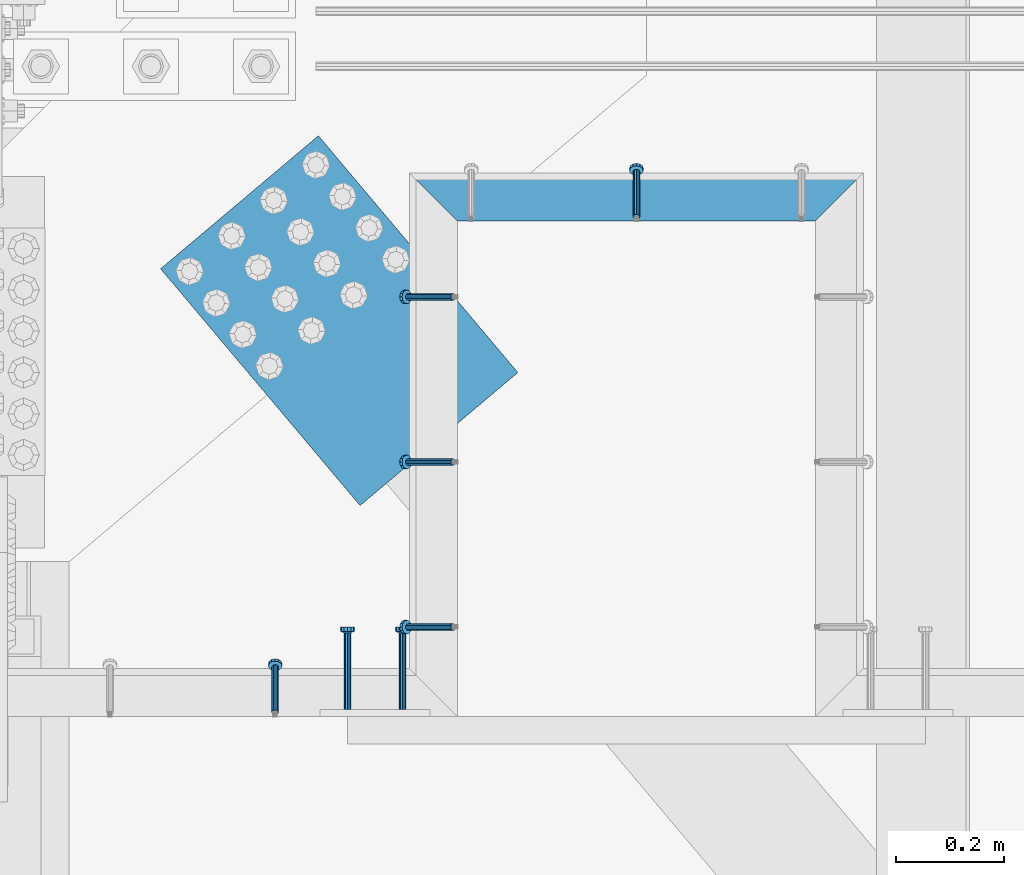
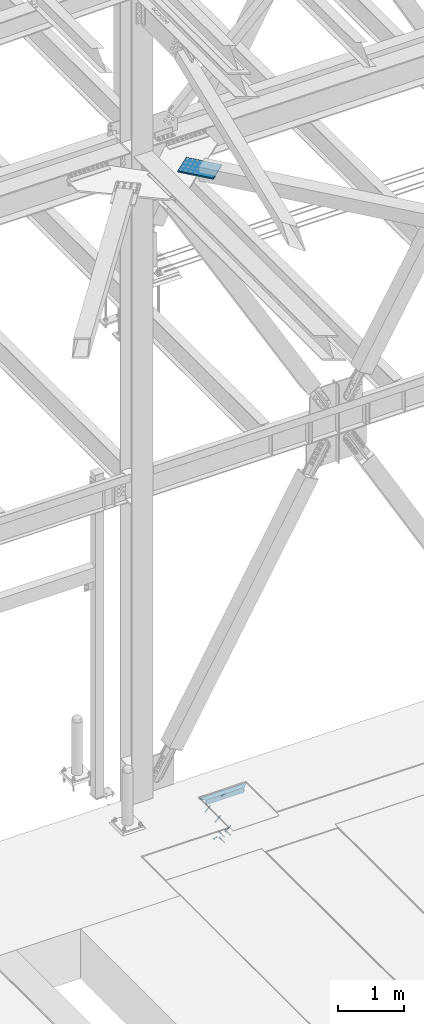
# One storey, part 2504 of 3843: 5 beams, 5 members, 5 elements without a shape of their own.
"""IFC2X3 building model written with IfcOpenShell, lengths in millimetres."""

from ifc_helpers import new_model, si_unit, frame, origin_with_axes, place, context, subcontext, project, spatial, faceted_brep, material, type_object, element, aggregate, save


model = new_model("IFC2X3")

# Units and contexts
model_context = context("Model", 3, precision=1e-05, world=origin_with_axes())
body_context = subcontext(model_context, "Body", "Model", "MODEL_VIEW")
ifc_project = project(units=[si_unit("LENGTHUNIT", "METRE", prefix="MILLI"), si_unit("AREAUNIT", "SQUARE_METRE"), si_unit("VOLUMEUNIT", "CUBIC_METRE"), si_unit("MASSUNIT", "GRAM", prefix="KILO"), si_unit("TIMEUNIT", "SECOND"), si_unit("PLANEANGLEUNIT", "RADIAN"), si_unit("SOLIDANGLEUNIT", "STERADIAN"), si_unit("THERMODYNAMICTEMPERATUREUNIT", "DEGREE_CELSIUS"), si_unit("LUMINOUSINTENSITYUNIT", "LUMEN")], contexts=[model_context])

# Site, building, storey
site_placement = place(None, origin_with_axes())
site = spatial("IfcSite", under=ifc_project, at=site_placement, CompositionType="ELEMENT")
building_placement = place(site_placement, origin_with_axes())
building = spatial("IfcBuilding", under=site, at=building_placement, Name="Undefined", CompositionType="ELEMENT")
storey_placement = place(building_placement, origin_with_axes())
storey = spatial("IfcBuildingStorey", under=building, at=storey_placement, Name="Undefined", CompositionType="ELEMENT", Elevation=0.0)

# Assembly, member
assembly_1_placement = place(storey_placement, origin_with_axes())
assembly_1 = element("IfcElementAssembly", 1, at=assembly_1_placement, inside=storey, Name="EMBED_ANGLE", AssemblyPlace="NOTDEFINED", PredefinedType="RIGID_FRAME")
ifc_material_1 = material(Name="STEEL/A108")
member_type = type_object("IfcMemberType", PredefinedType="NOTDEFINED")
member_1_placement = place(assembly_1_placement, frame((50197.5001822152, 91631.9607012059, 30446.6625), z_axis=(-1.0, 0.0, 0.0), x_axis=(5.70000238222118e-08, 0.707106781186546, -0.707106781186546)))
member_1 = element("IfcMember", 2, at=member_1_placement, type_object=member_type, material=ifc_material_1, Name="HEADED STUD ANCHOR", context=body_context, shape_type="Brep", body=[
    faceted_brep([(7.27595761418343e-12, -3.18000006675175, 5.5), (0.0, -5.49999999998363, 3.1800000667572), (118.110000000976, -5.49999999999091, 3.1800000667572), (118.110000000983, -3.18000006675175, 5.5), (0.0, -6.3499999046162, 0.0), (118.110000000968, -6.34999990461256, 0.0), (0.0, -5.49999999998363, -3.1800000667572), (118.110000000976, -5.49999999999091, -3.1800000667572), (7.27595761418343e-12, -3.18000006675175, -5.5), (118.110000000983, -3.18000006675175, -5.5), (7.27595761418343e-12, -1.81898940354586e-12, -6.34999990463257), (118.110000000968, -1.81898940354586e-12, -6.34999990463257), (0.0, 3.18000006675175, -5.5), (118.110000000968, 3.18000006674811, -5.5), (7.27595761418343e-12, 5.49999999998363, -3.1800000667572), (118.110000000983, 5.49999999998363, -3.1800000667572), (7.27595761418343e-12, 6.3499999046162, 0.0), (118.110000000976, 6.34999990461256, 0.0), (7.27595761418343e-12, 5.49999999998363, 3.1800000667572), (118.110000000983, 5.49999999998363, 3.1800000667572), (0.0, 3.18000006675175, 5.5), (118.110000000968, 3.18000006674811, 5.5), (7.27595761418343e-12, -1.81898940354586e-12, 6.34999990463257), (118.110000000968, -1.81898940354586e-12, 6.34999990463257), (120.650000000991, -10.9899997710909, 6.34999990463257), (120.650000000998, -6.34000015257152, 10.9899997711182), (120.650000000991, -12.6999998092379, 0.0), (120.650000000991, -10.9899997710909, -6.34999990463257), (120.650000000998, -6.34000015257152, -10.9899997711182), (120.650000000991, -1.81898940354586e-12, -12.6899995803833), (120.650000000991, 6.34000015257152, -10.9899997711182), (120.650000000998, 10.9899997710909, -6.34999990463257), (120.650000000991, 12.6999998092342, 0.0), (120.650000000998, 10.9899997710909, 6.34999990463257), (120.650000000991, 6.34000015257152, 10.9899997711182), (120.650000000991, -1.81898940354586e-12, 12.6899995803833), (127.000000001048, -10.9899997710945, 6.34999990463257), (127.000000001048, -6.34000015257152, 10.9899997711182), (127.000000001048, -12.6999998092342, 0.0), (127.000000001048, -10.9899997710945, -6.34999990463257), (127.000000001048, -6.34000015257152, -10.9899997711182), (127.000000001048, 1.81898940354586e-12, -12.6899995803833), (127.000000001048, 6.34000015256788, -10.9899997711182), (127.000000001048, 10.9899997710909, -6.34999990463257), (127.000000001048, 12.6999998092379, 0.0), (127.000000001048, 10.9899997710909, 6.34999990463257), (127.000000001048, 6.34000015256788, 10.9899997711182), (127.000000001048, 1.81898940354586e-12, 12.6899995803833)], [[[0, 1, 2, 3]], [[1, 4, 5, 2]], [[4, 6, 7, 5]], [[6, 8, 9, 7]], [[8, 10, 11, 9]], [[10, 12, 13, 11]], [[12, 14, 15, 13]], [[14, 16, 17, 15]], [[16, 18, 19, 17]], [[18, 20, 21, 19]], [[20, 22, 23, 21]], [[22, 0, 3, 23]], [[22, 20, 18, 16, 14, 12, 10, 8, 6, 4, 1, 0]], [[3, 2, 24, 25]], [[2, 5, 26, 24]], [[5, 7, 27, 26]], [[7, 9, 28, 27]], [[9, 11, 29, 28]], [[11, 13, 30, 29]], [[13, 15, 31, 30]], [[15, 17, 32, 31]], [[17, 19, 33, 32]], [[19, 21, 34, 33]], [[21, 23, 35, 34]], [[23, 3, 25, 35]], [[25, 24, 36, 37]], [[24, 26, 38, 36]], [[26, 27, 39, 38]], [[27, 28, 40, 39]], [[28, 29, 41, 40]], [[29, 30, 42, 41]], [[30, 31, 43, 42]], [[31, 32, 44, 43]], [[32, 33, 45, 44]], [[33, 34, 46, 45]], [[34, 35, 47, 46]], [[35, 25, 37, 47]], [[38, 39, 40, 41, 42, 43, 44, 45, 46, 47, 37, 36]]]),
])

# Assembly, members
assembly_2_placement = place(storey_placement, origin_with_axes())
assembly_2 = element("IfcElementAssembly", 3, at=assembly_2_placement, inside=storey, Name="EMBED_ANGLE", AssemblyPlace="NOTDEFINED", PredefinedType="RIGID_FRAME")
member_2_placement = place(assembly_2_placement, frame((49859.3745199416, 91484.3230038509, 30446.6625), z_axis=(0.0, -1.0, 0.0), x_axis=(-0.707106781186548, 0.0, -0.707106781186548)))
member_2 = element("IfcMember", 4, at=member_2_placement, type_object=member_type, material=ifc_material_1, Name="HEADED STUD ANCHOR", context=body_context, shape_type="Brep", body=[
    faceted_brep([(7.27595761418343e-12, -3.18000006675175, 5.5), (0.0, -5.49999999998363, 3.1800000667572), (118.110000000976, -5.49999999999091, 3.1800000667572), (118.110000000983, -3.18000006675175, 5.5), (0.0, -6.3499999046162, 0.0), (118.110000000968, -6.34999990461256, 0.0), (0.0, -5.49999999998363, -3.1800000667572), (118.110000000976, -5.49999999999091, -3.1800000667572), (7.27595761418343e-12, -3.18000006675175, -5.5), (118.110000000983, -3.18000006675175, -5.5), (7.27595761418343e-12, -1.81898940354586e-12, -6.34999990463257), (118.110000000968, -1.81898940354586e-12, -6.34999990463257), (0.0, 3.18000006675175, -5.5), (118.110000000968, 3.18000006674811, -5.5), (7.27595761418343e-12, 5.49999999998363, -3.1800000667572), (118.110000000983, 5.49999999998363, -3.1800000667572), (7.27595761418343e-12, 6.3499999046162, 0.0), (118.110000000976, 6.34999990461256, 0.0), (7.27595761418343e-12, 5.49999999998363, 3.1800000667572), (118.110000000983, 5.49999999998363, 3.1800000667572), (0.0, 3.18000006675175, 5.5), (118.110000000968, 3.18000006674811, 5.5), (7.27595761418343e-12, -1.81898940354586e-12, 6.34999990463257), (118.110000000968, -1.81898940354586e-12, 6.34999990463257), (120.650000000991, -10.9899997710909, 6.34999990463257), (120.650000000998, -6.34000015257152, 10.9899997711182), (120.650000000991, -12.6999998092379, 0.0), (120.650000000991, -10.9899997710909, -6.34999990463257), (120.650000000998, -6.34000015257152, -10.9899997711182), (120.650000000991, -1.81898940354586e-12, -12.6899995803833), (120.650000000991, 6.34000015257152, -10.9899997711182), (120.650000000998, 10.9899997710909, -6.34999990463257), (120.650000000991, 12.6999998092342, 0.0), (120.650000000998, 10.9899997710909, 6.34999990463257), (120.650000000991, 6.34000015257152, 10.9899997711182), (120.650000000991, -1.81898940354586e-12, 12.6899995803833), (127.000000001048, -10.9899997710945, 6.34999990463257), (127.000000001048, -6.34000015257152, 10.9899997711182), (127.000000001048, -12.6999998092342, 0.0), (127.000000001048, -10.9899997710945, -6.34999990463257), (127.000000001048, -6.34000015257152, -10.9899997711182), (127.000000001048, 1.81898940354586e-12, -12.6899995803833), (127.000000001048, 6.34000015256788, -10.9899997711182), (127.000000001048, 10.9899997710909, -6.34999990463257), (127.000000001048, 12.6999998092379, 0.0), (127.000000001048, 10.9899997710909, 6.34999990463257), (127.000000001048, 6.34000015256788, 10.9899997711182), (127.000000001048, 1.81898940354586e-12, 12.6899995803833)], [[[0, 1, 2, 3]], [[1, 4, 5, 2]], [[4, 6, 7, 5]], [[6, 8, 9, 7]], [[8, 10, 11, 9]], [[10, 12, 13, 11]], [[12, 14, 15, 13]], [[14, 16, 17, 15]], [[16, 18, 19, 17]], [[18, 20, 21, 19]], [[20, 22, 23, 21]], [[22, 0, 3, 23]], [[22, 20, 18, 16, 14, 12, 10, 8, 6, 4, 1, 0]], [[3, 2, 24, 25]], [[2, 5, 26, 24]], [[5, 7, 27, 26]], [[7, 9, 28, 27]], [[9, 11, 29, 28]], [[11, 13, 30, 29]], [[13, 15, 31, 30]], [[15, 17, 32, 31]], [[17, 19, 33, 32]], [[19, 21, 34, 33]], [[21, 23, 35, 34]], [[23, 3, 25, 35]], [[25, 24, 36, 37]], [[24, 26, 38, 36]], [[26, 27, 39, 38]], [[27, 28, 40, 39]], [[28, 29, 41, 40]], [[29, 30, 42, 41]], [[30, 31, 43, 42]], [[31, 32, 44, 43]], [[32, 33, 45, 44]], [[33, 34, 46, 45]], [[34, 35, 47, 46]], [[35, 25, 37, 47]], [[38, 39, 40, 41, 42, 43, 44, 45, 46, 47, 37, 36]]]),
])
member_3_placement = place(assembly_2_placement, frame((49859.3745199416, 91179.5230038509, 30446.6625), z_axis=(0.0, -1.0, 0.0), x_axis=(-0.707106781186548, 0.0, -0.707106781186548)))
member_3 = element("IfcMember", 5, at=member_3_placement, type_object=member_type, material=ifc_material_1, Name="HEADED STUD ANCHOR", context=body_context, shape_type="Brep", body=[
    faceted_brep([(7.27595761418343e-12, -3.18000006675175, 5.5), (0.0, -5.49999999998363, 3.1800000667572), (118.110000000976, -5.49999999999091, 3.1800000667572), (118.110000000983, -3.18000006675175, 5.5), (0.0, -6.3499999046162, 0.0), (118.110000000968, -6.34999990461256, 0.0), (0.0, -5.49999999998363, -3.1800000667572), (118.110000000976, -5.49999999999091, -3.1800000667572), (7.27595761418343e-12, -3.18000006675175, -5.5), (118.110000000983, -3.18000006675175, -5.5), (7.27595761418343e-12, -1.81898940354586e-12, -6.34999990463257), (118.110000000968, -1.81898940354586e-12, -6.34999990463257), (0.0, 3.18000006675175, -5.5), (118.110000000968, 3.18000006674811, -5.5), (7.27595761418343e-12, 5.49999999998363, -3.1800000667572), (118.110000000983, 5.49999999998363, -3.1800000667572), (7.27595761418343e-12, 6.3499999046162, 0.0), (118.110000000976, 6.34999990461256, 0.0), (7.27595761418343e-12, 5.49999999998363, 3.1800000667572), (118.110000000983, 5.49999999998363, 3.1800000667572), (0.0, 3.18000006675175, 5.5), (118.110000000968, 3.18000006674811, 5.5), (7.27595761418343e-12, -1.81898940354586e-12, 6.34999990463257), (118.110000000968, -1.81898940354586e-12, 6.34999990463257), (120.650000000991, -10.9899997710909, 6.34999990463257), (120.650000000998, -6.34000015257152, 10.9899997711182), (120.650000000991, -12.6999998092379, 0.0), (120.650000000991, -10.9899997710909, -6.34999990463257), (120.650000000998, -6.34000015257152, -10.9899997711182), (120.650000000991, -1.81898940354586e-12, -12.6899995803833), (120.650000000991, 6.34000015257152, -10.9899997711182), (120.650000000998, 10.9899997710909, -6.34999990463257), (120.650000000991, 12.6999998092342, 0.0), (120.650000000998, 10.9899997710909, 6.34999990463257), (120.650000000991, 6.34000015257152, 10.9899997711182), (120.650000000991, -1.81898940354586e-12, 12.6899995803833), (127.000000001048, -10.9899997710945, 6.34999990463257), (127.000000001048, -6.34000015257152, 10.9899997711182), (127.000000001048, -12.6999998092342, 0.0), (127.000000001048, -10.9899997710945, -6.34999990463257), (127.000000001048, -6.34000015257152, -10.9899997711182), (127.000000001048, 1.81898940354586e-12, -12.6899995803833), (127.000000001048, 6.34000015256788, -10.9899997711182), (127.000000001048, 10.9899997710909, -6.34999990463257), (127.000000001048, 12.6999998092379, 0.0), (127.000000001048, 10.9899997710909, 6.34999990463257), (127.000000001048, 6.34000015256788, 10.9899997711182), (127.000000001048, 1.81898940354586e-12, 12.6899995803833)], [[[0, 1, 2, 3]], [[1, 4, 5, 2]], [[4, 6, 7, 5]], [[6, 8, 9, 7]], [[8, 10, 11, 9]], [[10, 12, 13, 11]], [[12, 14, 15, 13]], [[14, 16, 17, 15]], [[16, 18, 19, 17]], [[18, 20, 21, 19]], [[20, 22, 23, 21]], [[22, 0, 3, 23]], [[22, 20, 18, 16, 14, 12, 10, 8, 6, 4, 1, 0]], [[3, 2, 24, 25]], [[2, 5, 26, 24]], [[5, 7, 27, 26]], [[7, 9, 28, 27]], [[9, 11, 29, 28]], [[11, 13, 30, 29]], [[13, 15, 31, 30]], [[15, 17, 32, 31]], [[17, 19, 33, 32]], [[19, 21, 34, 33]], [[21, 23, 35, 34]], [[23, 3, 25, 35]], [[25, 24, 36, 37]], [[24, 26, 38, 36]], [[26, 27, 39, 38]], [[27, 28, 40, 39]], [[28, 29, 41, 40]], [[29, 30, 42, 41]], [[30, 31, 43, 42]], [[31, 32, 44, 43]], [[32, 33, 45, 44]], [[33, 34, 46, 45]], [[34, 35, 47, 46]], [[35, 25, 37, 47]], [[38, 39, 40, 41, 42, 43, 44, 45, 46, 47, 37, 36]]]),
])
member_4_placement = place(assembly_2_placement, frame((49859.3745199416, 90874.7230038509, 30446.6625), z_axis=(0.0, -1.0, 0.0), x_axis=(-0.707106781186548, 0.0, -0.707106781186548)))
member_4 = element("IfcMember", 6, at=member_4_placement, type_object=member_type, material=ifc_material_1, Name="HEADED STUD ANCHOR", context=body_context, shape_type="Brep", body=[
    faceted_brep([(7.27595761418343e-12, -3.18000006675175, 5.5), (0.0, -5.49999999998363, 3.1800000667572), (118.110000000976, -5.49999999999091, 3.1800000667572), (118.110000000983, -3.18000006675175, 5.5), (0.0, -6.3499999046162, 0.0), (118.110000000968, -6.34999990461256, 0.0), (0.0, -5.49999999998363, -3.1800000667572), (118.110000000976, -5.49999999999091, -3.1800000667572), (7.27595761418343e-12, -3.18000006675175, -5.5), (118.110000000983, -3.18000006675175, -5.5), (7.27595761418343e-12, -1.81898940354586e-12, -6.34999990463257), (118.110000000968, -1.81898940354586e-12, -6.34999990463257), (0.0, 3.18000006675175, -5.5), (118.110000000968, 3.18000006674811, -5.5), (7.27595761418343e-12, 5.49999999998363, -3.1800000667572), (118.110000000983, 5.49999999998363, -3.1800000667572), (7.27595761418343e-12, 6.3499999046162, 0.0), (118.110000000976, 6.34999990461256, 0.0), (7.27595761418343e-12, 5.49999999998363, 3.1800000667572), (118.110000000983, 5.49999999998363, 3.1800000667572), (0.0, 3.18000006675175, 5.5), (118.110000000968, 3.18000006674811, 5.5), (7.27595761418343e-12, -1.81898940354586e-12, 6.34999990463257), (118.110000000968, -1.81898940354586e-12, 6.34999990463257), (120.650000000991, -10.9899997710909, 6.34999990463257), (120.650000000998, -6.34000015257152, 10.9899997711182), (120.650000000991, -12.6999998092379, 0.0), (120.650000000991, -10.9899997710909, -6.34999990463257), (120.650000000998, -6.34000015257152, -10.9899997711182), (120.650000000991, -1.81898940354586e-12, -12.6899995803833), (120.650000000991, 6.34000015257152, -10.9899997711182), (120.650000000998, 10.9899997710909, -6.34999990463257), (120.650000000991, 12.6999998092342, 0.0), (120.650000000998, 10.9899997710909, 6.34999990463257), (120.650000000991, 6.34000015257152, 10.9899997711182), (120.650000000991, -1.81898940354586e-12, 12.6899995803833), (127.000000001048, -10.9899997710945, 6.34999990463257), (127.000000001048, -6.34000015257152, 10.9899997711182), (127.000000001048, -12.6999998092342, 0.0), (127.000000001048, -10.9899997710945, -6.34999990463257), (127.000000001048, -6.34000015257152, -10.9899997711182), (127.000000001048, 1.81898940354586e-12, -12.6899995803833), (127.000000001048, 6.34000015256788, -10.9899997711182), (127.000000001048, 10.9899997710909, -6.34999990463257), (127.000000001048, 12.6999998092379, 0.0), (127.000000001048, 10.9899997710909, 6.34999990463257), (127.000000001048, 6.34000015256788, 10.9899997711182), (127.000000001048, 1.81898940354586e-12, 12.6899995803833)], [[[0, 1, 2, 3]], [[1, 4, 5, 2]], [[4, 6, 7, 5]], [[6, 8, 9, 7]], [[8, 10, 11, 9]], [[10, 12, 13, 11]], [[12, 14, 15, 13]], [[14, 16, 17, 15]], [[16, 18, 19, 17]], [[18, 20, 21, 19]], [[20, 22, 23, 21]], [[22, 0, 3, 23]], [[22, 20, 18, 16, 14, 12, 10, 8, 6, 4, 1, 0]], [[3, 2, 24, 25]], [[2, 5, 26, 24]], [[5, 7, 27, 26]], [[7, 9, 28, 27]], [[9, 11, 29, 28]], [[11, 13, 30, 29]], [[13, 15, 31, 30]], [[15, 17, 32, 31]], [[17, 19, 33, 32]], [[19, 21, 34, 33]], [[21, 23, 35, 34]], [[23, 3, 25, 35]], [[25, 24, 36, 37]], [[24, 26, 38, 36]], [[26, 27, 39, 38]], [[27, 28, 40, 39]], [[28, 29, 41, 40]], [[29, 30, 42, 41]], [[30, 31, 43, 42]], [[31, 32, 44, 43]], [[32, 33, 45, 44]], [[33, 34, 46, 45]], [[34, 35, 47, 46]], [[35, 25, 37, 47]], [[38, 39, 40, 41, 42, 43, 44, 45, 46, 47, 37, 36]]]),
])
aggregate(assembly_2, [member_2, member_3, member_4])

# Assembly, member
assembly_3_placement = place(storey_placement, origin_with_axes())
assembly_3 = element("IfcElementAssembly", 7, at=assembly_3_placement, inside=storey, Name="EMBED_ANGLE", AssemblyPlace="NOTDEFINED", PredefinedType="RIGID_FRAME")
member_5_placement = place(assembly_3_placement, frame((49530.7616210938, 90717.5605224609, 30446.6625), z_axis=(-1.0, 0.0, 0.0), x_axis=(5.70000238222118e-08, 0.707106781186546, -0.707106781186546)))
member_5 = element("IfcMember", 8, at=member_5_placement, type_object=member_type, material=ifc_material_1, Name="HEADED STUD ANCHOR", context=body_context, shape_type="Brep", body=[
    faceted_brep([(7.27595761418343e-12, -3.18000006675175, 5.5), (0.0, -5.49999999998363, 3.1800000667572), (118.110000000976, -5.49999999999091, 3.1800000667572), (118.110000000983, -3.18000006675175, 5.5), (0.0, -6.3499999046162, 0.0), (118.110000000968, -6.34999990461256, 0.0), (0.0, -5.49999999998363, -3.1800000667572), (118.110000000976, -5.49999999999091, -3.1800000667572), (7.27595761418343e-12, -3.18000006675175, -5.5), (118.110000000983, -3.18000006675175, -5.5), (7.27595761418343e-12, -1.81898940354586e-12, -6.34999990463257), (118.110000000968, -1.81898940354586e-12, -6.34999990463257), (0.0, 3.18000006675175, -5.5), (118.110000000968, 3.18000006674811, -5.5), (7.27595761418343e-12, 5.49999999998363, -3.1800000667572), (118.110000000983, 5.49999999998363, -3.1800000667572), (7.27595761418343e-12, 6.3499999046162, 0.0), (118.110000000976, 6.34999990461256, 0.0), (7.27595761418343e-12, 5.49999999998363, 3.1800000667572), (118.110000000983, 5.49999999998363, 3.1800000667572), (0.0, 3.18000006675175, 5.5), (118.110000000968, 3.18000006674811, 5.5), (7.27595761418343e-12, -1.81898940354586e-12, 6.34999990463257), (118.110000000968, -1.81898940354586e-12, 6.34999990463257), (120.650000000991, -10.9899997710909, 6.34999990463257), (120.650000000998, -6.34000015257152, 10.9899997711182), (120.650000000991, -12.6999998092379, 0.0), (120.650000000991, -10.9899997710909, -6.34999990463257), (120.650000000998, -6.34000015257152, -10.9899997711182), (120.650000000991, -1.81898940354586e-12, -12.6899995803833), (120.650000000991, 6.34000015257152, -10.9899997711182), (120.650000000998, 10.9899997710909, -6.34999990463257), (120.650000000991, 12.6999998092342, 0.0), (120.650000000998, 10.9899997710909, 6.34999990463257), (120.650000000991, 6.34000015257152, 10.9899997711182), (120.650000000991, -1.81898940354586e-12, 12.6899995803833), (127.000000001048, -10.9899997710945, 6.34999990463257), (127.000000001048, -6.34000015257152, 10.9899997711182), (127.000000001048, -12.6999998092342, 0.0), (127.000000001048, -10.9899997710945, -6.34999990463257), (127.000000001048, -6.34000015257152, -10.9899997711182), (127.000000001048, 1.81898940354586e-12, -12.6899995803833), (127.000000001048, 6.34000015256788, -10.9899997711182), (127.000000001048, 10.9899997710909, -6.34999990463257), (127.000000001048, 12.6999998092379, 0.0), (127.000000001048, 10.9899997710909, 6.34999990463257), (127.000000001048, 6.34000015256788, 10.9899997711182), (127.000000001048, 1.81898940354586e-12, 12.6899995803833)], [[[0, 1, 2, 3]], [[1, 4, 5, 2]], [[4, 6, 7, 5]], [[6, 8, 9, 7]], [[8, 10, 11, 9]], [[10, 12, 13, 11]], [[12, 14, 15, 13]], [[14, 16, 17, 15]], [[16, 18, 19, 17]], [[18, 20, 21, 19]], [[20, 22, 23, 21]], [[22, 0, 3, 23]], [[22, 20, 18, 16, 14, 12, 10, 8, 6, 4, 1, 0]], [[3, 2, 24, 25]], [[2, 5, 26, 24]], [[5, 7, 27, 26]], [[7, 9, 28, 27]], [[9, 11, 29, 28]], [[11, 13, 30, 29]], [[13, 15, 31, 30]], [[15, 17, 32, 31]], [[17, 19, 33, 32]], [[19, 21, 34, 33]], [[21, 23, 35, 34]], [[23, 3, 25, 35]], [[25, 24, 36, 37]], [[24, 26, 38, 36]], [[26, 27, 39, 38]], [[27, 28, 40, 39]], [[28, 29, 41, 40]], [[29, 30, 42, 41]], [[30, 31, 43, 42]], [[31, 32, 44, 43]], [[32, 33, 45, 44]], [[33, 34, 46, 45]], [[34, 35, 47, 46]], [[35, 25, 37, 47]], [[38, 39, 40, 41, 42, 43, 44, 45, 46, 47, 37, 36]]]),
])
aggregate(assembly_3, [member_5])

# Beam
ifc_material_2 = material(Name="STEEL/A36")
beam_type_1 = type_object("IfcBeamType", Name="L3-1/2X3-1/2X5/16", PredefinedType="NOTDEFINED")
beam_1_placement = place(assembly_1_placement, frame((49778.4120356608, 91668.4729859035, 30410.15), z_axis=(0.0, 0.0, -1.0), x_axis=(1.0, 0.0, 0.0)))
beam_1 = element("IfcBeam", 9, at=beam_1_placement, type_object=beam_type_1, material=ifc_material_2, Name="EMBED_ANGLE", ObjectType="L3-1/2X3-1/2X5/16", context=body_context, shape_type="Brep", body=[
    faceted_brep([(88.8999999971129, 44.4500000000007, -44.4499999999971), (88.8999999965163, 44.4499999999971, 44.4500000000007), (749.276214386591, 44.4499999979453, 44.4500000000007), (749.276214386591, 44.4499999979453, -44.4500000000007), (80.9624999965163, 36.5124999999971, 44.4500000000007), (757.213718101135, 36.5124999979162, 44.4500000000007), (80.9624999971129, 36.5125000000007, -36.5124999999971), (757.213718101135, 36.5124999979162, -36.5125000000007), (3.63797880709171e-12, -44.4499999999971, -36.5125000000007), (838.176255989529, -44.4500000023108, -36.5125000000007), (3.63797880709171e-12, -44.4499999999971, -44.4500000000007), (838.176255989529, -44.4500000023108, -44.4500000000007)], [[[0, 1, 2, 3]], [[1, 4, 5, 2]], [[4, 6, 7, 5]], [[6, 8, 9, 7]], [[8, 10, 11, 9]], [[10, 0, 3, 11]], [[5, 7, 9, 11, 3, 2]], [[10, 8, 6, 4, 1, 0]]]),
])

aggregate(assembly_1, [member_1, beam_1])

# Assembly, beam
assembly_4_placement = place(storey_placement, origin_with_axes())
assembly_4 = element("IfcElementAssembly", 10, at=assembly_4_placement, inside=storey, AssemblyPlace="NOTDEFINED", PredefinedType="RIGID_FRAME")
ifc_material_3 = material(Name="STEEL/A572-50")
beam_type_2 = type_object("IfcBeamType", PredefinedType="NOTDEFINED")
beam_2_placement = place(assembly_4_placement, frame((49464.9023047379, 91658.912649077, 42259.25), z_axis=(-0.764727548108139, -0.644353767091118, 0.0), x_axis=(0.644353767091114, -0.764727548108142, 0.0)))
beam_2 = element("IfcBeam", 11, at=beam_2_placement, type_object=beam_type_2, material=ifc_material_3, Name="PLATE", context=body_context, shape_type="Brep", body=[
    faceted_brep([(5.85714587941766e-10, 12.6999999999971, -190.500000000349), (-6.14818418398499e-10, 12.6999999999971, 190.500000000364), (571.499999996191, 12.6999999999971, 190.49999999936), (571.499999997392, 12.6999999999971, -190.500000001353), (-6.14818418398499e-10, -12.6999999999971, 190.500000000364), (571.499999996191, -12.6999999999971, 190.49999999936), (5.85714587941766e-10, -12.6999999999971, -190.500000000349), (571.499999997392, -12.6999999999971, -190.500000001353)], [[[0, 1, 2, 3]], [[1, 4, 5, 2]], [[4, 6, 7, 5]], [[6, 0, 3, 7]], [[5, 7, 3, 2]], [[6, 4, 1, 0]]]),
])
aggregate(assembly_4, [beam_2])

# Assembly, beams
assembly_5_placement = place(storey_placement, origin_with_axes())
assembly_5 = element("IfcElementAssembly", 12, at=assembly_5_placement, inside=storey, Name="EMBED PLATE", AssemblyPlace="NOTDEFINED", PredefinedType="RIGID_FRAME")
beam_type_3 = type_object("IfcBeamType", PredefinedType="NOTDEFINED")
beam_3_placement = place(assembly_5_placement, frame((49664.1120576172, 90722.3230224609, 30394.275), z_axis=(-1.0, 0.0, 0.0), x_axis=(0.0, 1.0, 0.0)))
beam_3 = element("IfcBeam", 13, at=beam_3_placement, type_object=beam_type_3, material=ifc_material_1, Name="HEADED STUD ANCHOR", context=body_context, shape_type="Brep", body=[
    faceted_brep([(7.27595761418343e-12, -3.18000006675175, 5.5), (0.0, -5.49999999998363, 3.1800000667572), (141.731999999989, -5.5, 3.1800000667572), (141.731999999989, -3.1800000667572, 5.5), (0.0, -6.3499999046162, 0.0), (141.731999999989, -6.34999990463257, 0.0), (0.0, -5.49999999998363, -3.1800000667572), (141.731999999989, -5.5, -3.1800000667572), (7.27595761418343e-12, -3.18000006675175, -5.5), (141.731999999989, -3.1800000667572, -5.5), (7.27595761418343e-12, -1.81898940354586e-12, -6.34999990463257), (141.731999999989, 0.0, -6.34999990463257), (0.0, 3.18000006675175, -5.5), (141.731999999989, 3.1800000667572, -5.5), (7.27595761418343e-12, 5.49999999998363, -3.1800000667572), (141.731999999989, 5.5, -3.1800000667572), (7.27595761418343e-12, 6.3499999046162, 0.0), (141.731999999989, 6.34999990463257, 0.0), (7.27595761418343e-12, 5.49999999998363, 3.1800000667572), (141.731999999989, 5.5, 3.1800000667572), (0.0, 3.18000006675175, 5.5), (141.731999999989, 3.1800000667572, 5.5), (7.27595761418343e-12, -1.81898940354586e-12, 6.34999990463257), (141.731999999989, 0.0, 6.34999990463257), (144.779999999999, -10.9899997711182, 6.34999990463257), (144.779999999999, -6.34000015258789, 10.9899997711182), (144.779999999999, -12.6999998092651, 0.0), (144.779999999999, -10.9899997711182, -6.34999990463257), (144.779999999999, -6.34000015258789, -10.9899997711182), (144.779999999999, 0.0, -12.6899995803833), (144.779999999999, 6.34000015258789, -10.9899997711182), (144.779999999999, 10.9899997711182, -6.34999990463257), (144.779999999999, 12.6999998092651, 0.0), (144.779999999999, 10.9899997711182, 6.34999990463257), (144.779999999999, 6.34000015258789, 10.9899997711182), (144.779999999999, 0.0, 12.6899995803833), (152.399999999994, -10.9899997711182, 6.34999990463257), (152.399999999994, -6.34000015258789, 10.9899997711182), (152.399999999994, -12.6999998092651, 0.0), (152.399999999994, -10.9899997711182, -6.34999990463257), (152.399999999994, -6.34000015258789, -10.9899997711182), (152.399999999994, 0.0, -12.6899995803833), (152.399999999994, 6.34000015258789, -10.9899997711182), (152.399999999994, 10.9899997711182, -6.34999990463257), (152.399999999994, 12.6999998092651, 0.0), (152.399999999994, 10.9899997711182, 6.34999990463257), (152.399999999994, 6.34000015258789, 10.9899997711182), (152.399999999994, 0.0, 12.6899995803833)], [[[0, 1, 2, 3]], [[1, 4, 5, 2]], [[4, 6, 7, 5]], [[6, 8, 9, 7]], [[8, 10, 11, 9]], [[10, 12, 13, 11]], [[12, 14, 15, 13]], [[14, 16, 17, 15]], [[16, 18, 19, 17]], [[18, 20, 21, 19]], [[20, 22, 23, 21]], [[22, 0, 3, 23]], [[22, 20, 18, 16, 14, 12, 10, 8, 6, 4, 1, 0]], [[3, 2, 24, 25]], [[2, 5, 26, 24]], [[5, 7, 27, 26]], [[7, 9, 28, 27]], [[9, 11, 29, 28]], [[11, 13, 30, 29]], [[13, 15, 31, 30]], [[15, 17, 32, 31]], [[17, 19, 33, 32]], [[19, 21, 34, 33]], [[21, 23, 35, 34]], [[23, 3, 25, 35]], [[25, 24, 36, 37]], [[24, 26, 38, 36]], [[26, 27, 39, 38]], [[27, 28, 40, 39]], [[28, 29, 41, 40]], [[29, 30, 42, 41]], [[30, 31, 43, 42]], [[31, 32, 44, 43]], [[32, 33, 45, 44]], [[33, 34, 46, 45]], [[34, 35, 47, 46]], [[35, 25, 37, 47]], [[38, 39, 40, 41, 42, 43, 44, 45, 46, 47, 37, 36]]]),
])
beam_4_placement = place(assembly_5_placement, frame((49664.1120576172, 90722.3230224609, 30292.675), z_axis=(-1.0, 0.0, 0.0), x_axis=(0.0, 1.0, 0.0)))
beam_4 = element("IfcBeam", 14, at=beam_4_placement, type_object=beam_type_3, material=ifc_material_1, Name="HEADED STUD ANCHOR", context=body_context, shape_type="Brep", body=[
    faceted_brep([(7.27595761418343e-12, -3.18000006675175, 5.5), (0.0, -5.49999999998363, 3.1800000667572), (141.731999999989, -5.5, 3.1800000667572), (141.731999999989, -3.1800000667572, 5.5), (0.0, -6.3499999046162, 0.0), (141.731999999989, -6.34999990463257, 0.0), (0.0, -5.49999999998363, -3.1800000667572), (141.731999999989, -5.5, -3.1800000667572), (7.27595761418343e-12, -3.18000006675175, -5.5), (141.731999999989, -3.1800000667572, -5.5), (7.27595761418343e-12, -1.81898940354586e-12, -6.34999990463257), (141.731999999989, 0.0, -6.34999990463257), (0.0, 3.18000006675175, -5.5), (141.731999999989, 3.1800000667572, -5.5), (7.27595761418343e-12, 5.49999999998363, -3.1800000667572), (141.731999999989, 5.5, -3.1800000667572), (7.27595761418343e-12, 6.3499999046162, 0.0), (141.731999999989, 6.34999990463257, 0.0), (7.27595761418343e-12, 5.49999999998363, 3.1800000667572), (141.731999999989, 5.5, 3.1800000667572), (0.0, 3.18000006675175, 5.5), (141.731999999989, 3.1800000667572, 5.5), (7.27595761418343e-12, -1.81898940354586e-12, 6.34999990463257), (141.731999999989, 0.0, 6.34999990463257), (144.779999999999, -10.9899997711182, 6.34999990463257), (144.779999999999, -6.34000015258789, 10.9899997711182), (144.779999999999, -12.6999998092651, 0.0), (144.779999999999, -10.9899997711182, -6.34999990463257), (144.779999999999, -6.34000015258789, -10.9899997711182), (144.779999999999, 0.0, -12.6899995803833), (144.779999999999, 6.34000015258789, -10.9899997711182), (144.779999999999, 10.9899997711182, -6.34999990463257), (144.779999999999, 12.6999998092651, 0.0), (144.779999999999, 10.9899997711182, 6.34999990463257), (144.779999999999, 6.34000015258789, 10.9899997711182), (144.779999999999, 0.0, 12.6899995803833), (152.399999999994, -10.9899997711182, 6.34999990463257), (152.399999999994, -6.34000015258789, 10.9899997711182), (152.399999999994, -12.6999998092651, 0.0), (152.399999999994, -10.9899997711182, -6.34999990463257), (152.399999999994, -6.34000015258789, -10.9899997711182), (152.399999999994, 0.0, -12.6899995803833), (152.399999999994, 6.34000015258789, -10.9899997711182), (152.399999999994, 10.9899997711182, -6.34999990463257), (152.399999999994, 12.6999998092651, 0.0), (152.399999999994, 10.9899997711182, 6.34999990463257), (152.399999999994, 6.34000015258789, 10.9899997711182), (152.399999999994, 0.0, 12.6899995803833)], [[[0, 1, 2, 3]], [[1, 4, 5, 2]], [[4, 6, 7, 5]], [[6, 8, 9, 7]], [[8, 10, 11, 9]], [[10, 12, 13, 11]], [[12, 14, 15, 13]], [[14, 16, 17, 15]], [[16, 18, 19, 17]], [[18, 20, 21, 19]], [[20, 22, 23, 21]], [[22, 0, 3, 23]], [[22, 20, 18, 16, 14, 12, 10, 8, 6, 4, 1, 0]], [[3, 2, 24, 25]], [[2, 5, 26, 24]], [[5, 7, 27, 26]], [[7, 9, 28, 27]], [[9, 11, 29, 28]], [[11, 13, 30, 29]], [[13, 15, 31, 30]], [[15, 17, 32, 31]], [[17, 19, 33, 32]], [[19, 21, 34, 33]], [[21, 23, 35, 34]], [[23, 3, 25, 35]], [[25, 24, 36, 37]], [[24, 26, 38, 36]], [[26, 27, 39, 38]], [[27, 28, 40, 39]], [[28, 29, 41, 40]], [[29, 30, 42, 41]], [[30, 31, 43, 42]], [[31, 32, 44, 43]], [[32, 33, 45, 44]], [[33, 34, 46, 45]], [[34, 35, 47, 46]], [[35, 25, 37, 47]], [[38, 39, 40, 41, 42, 43, 44, 45, 46, 47, 37, 36]]]),
])
beam_5_placement = place(assembly_5_placement, frame((49765.7120576172, 90722.3230224609, 30394.275), z_axis=(-1.0, 0.0, 0.0), x_axis=(0.0, 1.0, 0.0)))
beam_5 = element("IfcBeam", 15, at=beam_5_placement, type_object=beam_type_3, material=ifc_material_1, Name="HEADED STUD ANCHOR", context=body_context, shape_type="Brep", body=[
    faceted_brep([(7.27595761418343e-12, -3.18000006675175, 5.5), (0.0, -5.49999999998363, 3.1800000667572), (141.731999999989, -5.5, 3.1800000667572), (141.731999999989, -3.1800000667572, 5.5), (0.0, -6.3499999046162, 0.0), (141.731999999989, -6.34999990463257, 0.0), (0.0, -5.49999999998363, -3.1800000667572), (141.731999999989, -5.5, -3.1800000667572), (7.27595761418343e-12, -3.18000006675175, -5.5), (141.731999999989, -3.1800000667572, -5.5), (7.27595761418343e-12, -1.81898940354586e-12, -6.34999990463257), (141.731999999989, 0.0, -6.34999990463257), (0.0, 3.18000006675175, -5.5), (141.731999999989, 3.1800000667572, -5.5), (7.27595761418343e-12, 5.49999999998363, -3.1800000667572), (141.731999999989, 5.5, -3.1800000667572), (7.27595761418343e-12, 6.3499999046162, 0.0), (141.731999999989, 6.34999990463257, 0.0), (7.27595761418343e-12, 5.49999999998363, 3.1800000667572), (141.731999999989, 5.5, 3.1800000667572), (0.0, 3.18000006675175, 5.5), (141.731999999989, 3.1800000667572, 5.5), (7.27595761418343e-12, -1.81898940354586e-12, 6.34999990463257), (141.731999999989, 0.0, 6.34999990463257), (144.779999999999, -10.9899997711182, 6.34999990463257), (144.779999999999, -6.34000015258789, 10.9899997711182), (144.779999999999, -12.6999998092651, 0.0), (144.779999999999, -10.9899997711182, -6.34999990463257), (144.779999999999, -6.34000015258789, -10.9899997711182), (144.779999999999, 0.0, -12.6899995803833), (144.779999999999, 6.34000015258789, -10.9899997711182), (144.779999999999, 10.9899997711182, -6.34999990463257), (144.779999999999, 12.6999998092651, 0.0), (144.779999999999, 10.9899997711182, 6.34999990463257), (144.779999999999, 6.34000015258789, 10.9899997711182), (144.779999999999, 0.0, 12.6899995803833), (152.399999999994, -10.9899997711182, 6.34999990463257), (152.399999999994, -6.34000015258789, 10.9899997711182), (152.399999999994, -12.6999998092651, 0.0), (152.399999999994, -10.9899997711182, -6.34999990463257), (152.399999999994, -6.34000015258789, -10.9899997711182), (152.399999999994, 0.0, -12.6899995803833), (152.399999999994, 6.34000015258789, -10.9899997711182), (152.399999999994, 10.9899997711182, -6.34999990463257), (152.399999999994, 12.6999998092651, 0.0), (152.399999999994, 10.9899997711182, 6.34999990463257), (152.399999999994, 6.34000015258789, 10.9899997711182), (152.399999999994, 0.0, 12.6899995803833)], [[[0, 1, 2, 3]], [[1, 4, 5, 2]], [[4, 6, 7, 5]], [[6, 8, 9, 7]], [[8, 10, 11, 9]], [[10, 12, 13, 11]], [[12, 14, 15, 13]], [[14, 16, 17, 15]], [[16, 18, 19, 17]], [[18, 20, 21, 19]], [[20, 22, 23, 21]], [[22, 0, 3, 23]], [[22, 20, 18, 16, 14, 12, 10, 8, 6, 4, 1, 0]], [[3, 2, 24, 25]], [[2, 5, 26, 24]], [[5, 7, 27, 26]], [[7, 9, 28, 27]], [[9, 11, 29, 28]], [[11, 13, 30, 29]], [[13, 15, 31, 30]], [[15, 17, 32, 31]], [[17, 19, 33, 32]], [[19, 21, 34, 33]], [[21, 23, 35, 34]], [[23, 3, 25, 35]], [[25, 24, 36, 37]], [[24, 26, 38, 36]], [[26, 27, 39, 38]], [[27, 28, 40, 39]], [[28, 29, 41, 40]], [[29, 30, 42, 41]], [[30, 31, 43, 42]], [[31, 32, 44, 43]], [[32, 33, 45, 44]], [[33, 34, 46, 45]], [[34, 35, 47, 46]], [[35, 25, 37, 47]], [[38, 39, 40, 41, 42, 43, 44, 45, 46, 47, 37, 36]]]),
])
aggregate(assembly_5, [beam_3, beam_4, beam_5])

save(model, "model.ifc")
